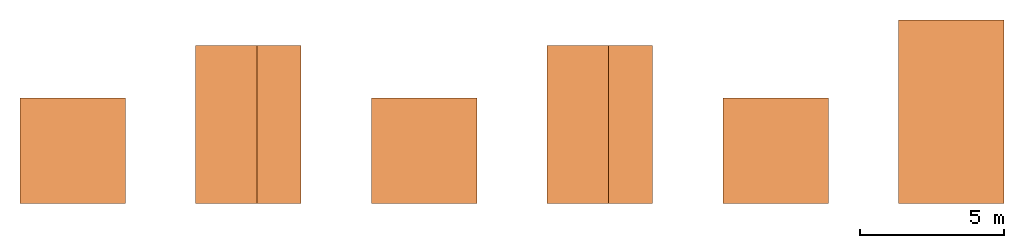
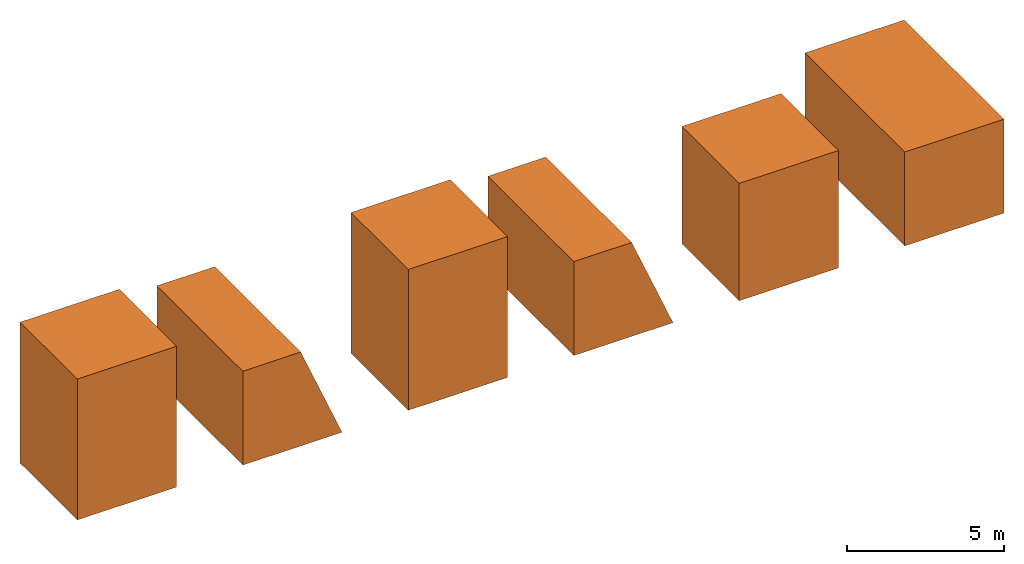
# One storey: 6 proxies.
"""IFC2X3 building model written with IfcOpenShell, lengths in feet."""

from ifc_helpers import new_model, entity, si_unit, converted_unit, frame, frame_2d, origin_with_axes, place, context, subcontext, project, spatial, polyline, outline, extrude, element, save


model = new_model("IFC2X3")

# Units and contexts
model_context = context("Model", 3, precision=1e-05, world=origin_with_axes())
plan_context = context("Plan", 2, precision=1e-05, world=frame_2d((0.0, 0.0, 0.0), x_axis=(1.0, 0.0, 0.0)))
body_context = subcontext(model_context, "Body", "Model", "MODEL_VIEW")
ifc_project = project(units=[converted_unit("LENGTHUNIT", "foot", entity("IfcReal", 0.3048), si_unit("LENGTHUNIT", "METRE"), dimensions=[1, 0, 0, 0, 0, 0, 0]), converted_unit("VOLUMEUNIT", "cubic foot", entity("IfcReal", 0.0283168467116885), si_unit("VOLUMEUNIT", "CUBIC_METRE"), dimensions=[3, 0, 0, 0, 0, 0, 0]), converted_unit("AREAUNIT", "square foot", entity("IfcReal", 0.09290304), si_unit("AREAUNIT", "SQUARE_METRE"), dimensions=[2, 0, 0, 0, 0, 0, 0])], contexts=[model_context, plan_context])

# Site, building, storey
site_placement = place(None, origin_with_axes())
site = spatial("IfcSite", under=ifc_project, at=site_placement, CompositionType="ELEMENT")
building_placement = place(site_placement, origin_with_axes())
building = spatial("IfcBuilding", under=site, at=building_placement, Name="Building", CompositionType="ELEMENT")
storey_placement = place(building_placement, origin_with_axes())
storey = spatial("IfcBuildingStorey", under=building, at=storey_placement, Name="Storey", CompositionType="ELEMENT")

# Proxies
proxy_1_placement = place(storey_placement, origin_with_axes())
element("IfcBuildingElementProxy", 1, at=proxy_1_placement, inside=storey, Name="Cube", context=body_context, shape_type="SweptSolid", body=[
    extrude(outline(polyline([(-6.00000026970711, -5.99999987860051), (6.00000026970711, -5.99999987860051), (6.00000026970711, 5.99999987860051), (-6.00000026970711, 5.99999987860051), (-6.00000026970711, -5.99999987860051)])), frame((-6.00000026970711, 5.99999987860051, 0.0), z_axis=(0.0, 0.0, -1.0), x_axis=(-1.0, 0.0, 0.0)), (0.0, 0.0, -1.0), 15.0000003195974),
])
proxy_2_placement = place(storey_placement, frame((19.9999990738596, 0.0, 12.0000013216274), z_axis=(0.0, 1.0, -1.62920684942947e-07), x_axis=(1.0, 0.0, 0.0)))
element("IfcBuildingElementProxy", 2, at=proxy_2_placement, inside=storey, Name="Cube", context=body_context, shape_type="SweptSolid", body=[
    extrude(outline(polyline([(-6.00000026970711, -5.99999987860051), (6.00000026970711, -5.99999987860051), (6.00000026970711, 5.99999987860051), (-6.00000026970711, 5.99999987860051), (-6.00000026970711, -5.99999987860051)])), frame((-6.00000026970711, 5.99999987860051, 0.0), z_axis=(0.0, 0.0, -1.0), x_axis=(-1.0, 0.0, 0.0)), (0.0, 0.0, -1.0), 20.899999401665),
])
proxy_3_placement = place(storey_placement, frame((-40.0000012765719, 1.72544673212427e-07, -1.80875460424441e-07), z_axis=(0.0, 0.0, 1.0), x_axis=(1.0, 0.0, 0.0)))
element("IfcBuildingElementProxy", 3, at=proxy_3_placement, inside=storey, Name="Cube", context=body_context, shape_type="SweptSolid", body=[
    extrude(outline(polyline([(-6.00000026970711, -5.99999987860051), (6.00000026970711, -5.99999987860051), (6.00000026970711, 5.99999987860051), (-6.00000026970711, 5.99999987860051), (-6.00000026970711, -5.99999987860051)])), frame((-6.00000026970711, 5.99999987860051, 0.0), z_axis=(0.0, 0.0, -1.0), x_axis=(-1.0, 0.0, 0.0)), (0.0, 0.0, -1.0), 18.0),
])
proxy_4_placement = place(storey_placement, frame((-20.0000022027123, 1.72544673212427e-07, 12.0000013216274), z_axis=(0.0, 1.0, -1.62920684942947e-07), x_axis=(1.0, 0.0, 0.0)))
element("IfcBuildingElementProxy", 4, at=proxy_4_placement, inside=storey, Name="Cube", context=body_context, shape_type="SweptSolid", body=[
    extrude(outline(polyline([(-2.25000024780514, -5.99999987860051), (4.74999974093099, -5.99999987860051), (4.74999974093099, 5.99999987860051), (-7.25000079848322, 5.99999987860051), (-2.25000024780514, -5.99999987860051)])), frame((-7.25000079848322, 5.99999987860051, 0.0), z_axis=(0.0, 0.0, -1.0), x_axis=(-1.0, 0.0, 0.0)), (0.0, 0.0, -1.0), 18.0),
])
proxy_5_placement = place(storey_placement, frame((-66.0000072689507, 6.00000026970711, 5.99999831417414), z_axis=(0.0, 1.0, -1.62920684942947e-07), x_axis=(1.0, 0.0, 0.0)))
element("IfcBuildingElementProxy", 5, at=proxy_5_placement, inside=storey, Name="Cube", context=body_context, shape_type="SweptSolid", body=[
    extrude(outline(polyline([(-4.7499993498244, -5.99999948749392), (7.24999923405685, -5.99999948749392), (2.24999907448536, 5.99999987860051), (-4.7499993498244, 5.99999948749392), (-4.7499993498244, -5.99999948749392)])), frame((-1.25000013766952, -9.77766482535935e-08, -5.99999948749392), z_axis=(0.0, 0.0, -1.0), x_axis=(1.0, 0.0, 0.0)), (0.0, 0.0, -1.0), 18.0),
])
proxy_6_placement = place(storey_placement, frame((-86.000009471663, 5.99999948749392, 5.99999948749392), z_axis=(0.0, 0.0, 1.0), x_axis=(1.0, 0.0, 0.0)))
element("IfcBuildingElementProxy", 6, at=proxy_6_placement, inside=storey, Name="Cube", context=body_context, shape_type="SweptSolid", body=[
    extrude(outline(polyline([(-5.99999948749392, -5.99999948749392), (5.99999948749392, -5.99999948749392), (5.99999948749392, 5.99999948749392), (-5.99999948749392, 5.99999948749392), (-5.99999948749392, -5.99999948749392)])), frame((0.0, 0.0, -5.99999948749392), z_axis=(0.0, 0.0, -1.0), x_axis=(1.0, 0.0, 0.0)), (0.0, 0.0, -1.0), 18.0),
])

save(model, "model.ifc")
